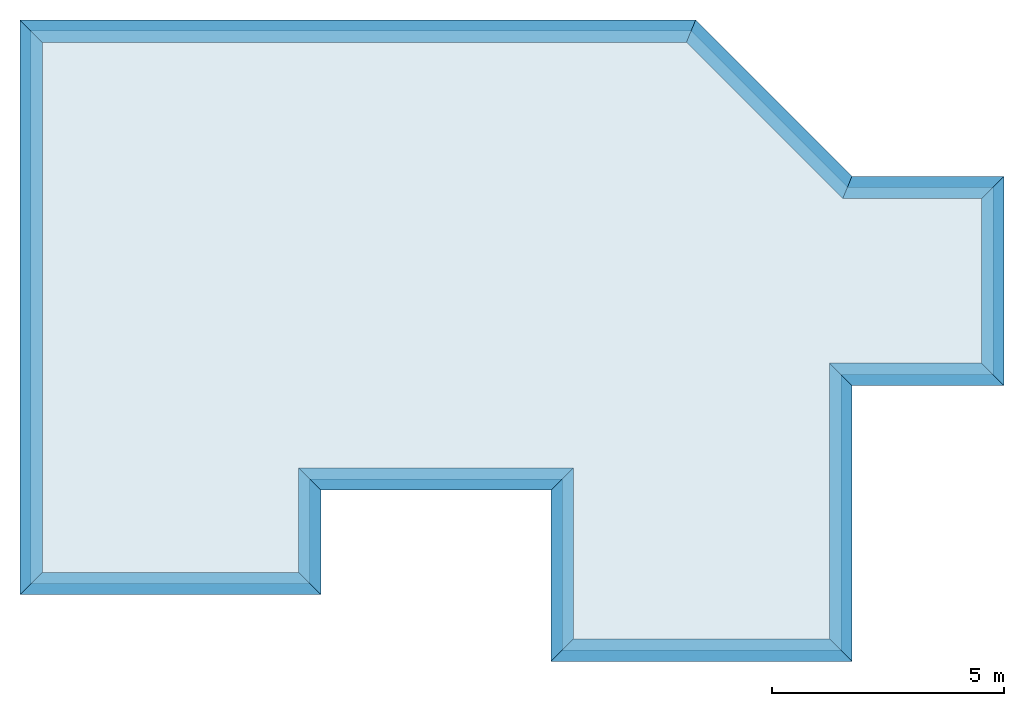
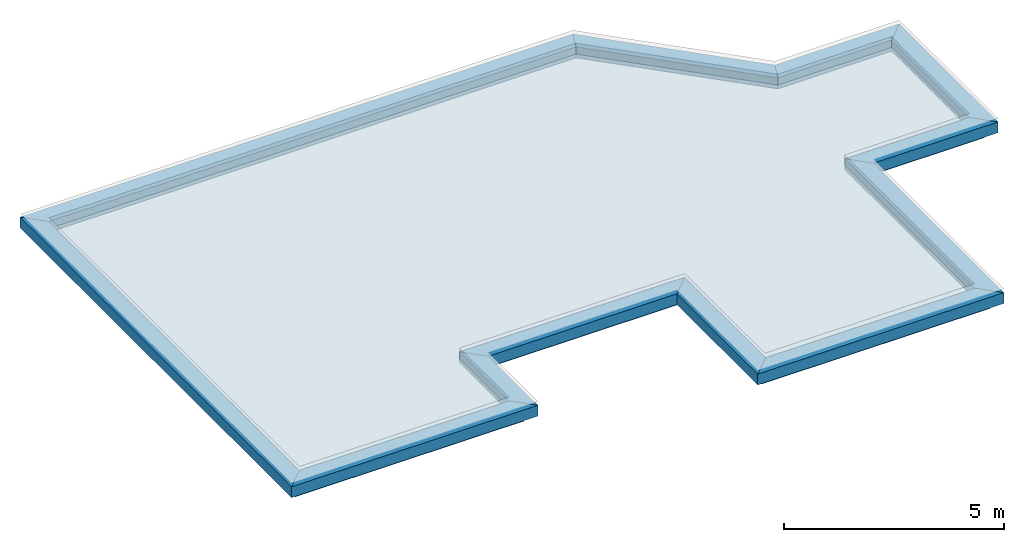
# One storey, part 1 of 3: 12 walls, 1 slab.
"""IFC4 building model written with IfcOpenShell, lengths in millimetres."""

from ifc_helpers import new_model, entity, si_unit, converted_unit, frame, origin_with_axes, origin_2d_with_axis, place, context, subcontext, project, spatial, line, indexed_curve, outline, extrude, material, layer, layer_set, layer_usage, type_object, element, save


model = new_model("IFC4")

# Units and contexts
model_context = context("Model", 3, precision=1e-05, world=origin_with_axes())
plan_context = context("Plan", 2, precision=1e-05, world=origin_2d_with_axis())
body_context = subcontext(model_context, "Body", "Model", "MODEL_VIEW")
ifc_project = project(units=[si_unit("VOLUMEUNIT", "CUBIC_METRE"), si_unit("LENGTHUNIT", "METRE", prefix="MILLI"), converted_unit("PLANEANGLEUNIT", "degree", entity("IfcReal", 0.0174532925199433), si_unit("PLANEANGLEUNIT", "RADIAN"), dimensions=[0, 0, 0, 0, 0, 0, 0]), si_unit("AREAUNIT", "SQUARE_METRE")], contexts=[model_context, plan_context])

# Site, building, storey
site_placement = place(None, origin_with_axes())
site = spatial("IfcSite", under=ifc_project, at=site_placement)
building_placement = place(site_placement, origin_with_axes())
building = spatial("IfcBuilding", under=site, at=building_placement, Name="Building")
storey_placement = place(building_placement, frame((0.0, 0.0, 2894.99998092651), z_axis=(0.0, 0.0, 1.0), x_axis=(1.0, 0.0, 0.0)))
storey = spatial("IfcBuildingStorey", under=building, at=storey_placement, Name="Dach")

# Slab
ifc_material_1 = material(Name="Beton")
ifc_layer_1 = layer(ifc_material_1, 200.0, Name="Dach Beton", Priority=10)
ifc_layer_set_1 = layer_set([ifc_layer_1], Name="Dach")
ifc_layer_usage_1 = layer_usage(ifc_layer_set_1, "AXIS3", "POSITIVE", -200.0)
slab_placement = place(storey_placement, frame((-229.997292160988, -229.997798800468, 200.000047683716), z_axis=(0.0, 0.0, 1.0), x_axis=(1.0, 0.0, 0.0)))
element("IfcSlab", 1, at=slab_placement, inside=storey, material=ifc_layer_usage_1, Name="Slab", context=body_context, shape_type="SweptSolid", body=[
    extrude(outline(indexed_curve([(229.999893188477, -170.00212097168), (229.996322631836, 11729.9970703125), (14436.1923828125, 11729.9951171875), (17798.134765625, 8368.0556640625), (20933.404296875, 8368.056640625), (20933.404296875, 4328.05712890625), (17663.404296875, 4328.05615234375), (17663.404296875, -1601.94250488281), (11652.25390625, -1601.94250488281), (11652.25390625, 2078.05444335938), (6241.12548828125, 2078.05444335938), (6241.12548828125, -170.00212097168), (229.999893188477, -170.00212097168)])), frame((0.0, 0.0, -200.0), z_axis=(0.0, 0.0, 1.0), x_axis=(1.0, 0.0, 0.0)), (0.0, 0.0, 1.0), 200.0),
])

# Walls
ifc_material_2 = material(Name="Ziegel")
ifc_layer_2 = layer(ifc_material_2, 250.0, Name="Ziegel", Priority=10)
ifc_material_3 = material()
ifc_layer_3 = layer(ifc_material_3, 200.0, Priority=1)
ifc_material_4 = material()
ifc_layer_4 = layer(ifc_material_4, 30.0000019073486, Priority=1)
ifc_layer_set_2 = layer_set([ifc_layer_2, ifc_layer_3, ifc_layer_4], Name="Wand Aussen")
ifc_layer_usage_2 = layer_usage(ifc_layer_set_2, "AXIS2", "NEGATIVE", 0.0)
wall_type = type_object("IfcWallType", Name="Attika Wand", PredefinedType="SOLIDWALL", material=ifc_layer_set_2)
wall_1_placement = place(storey_placement, frame((20453.4070428786, 7888.05856506086, 200.000047683719), z_axis=(0.0, 0.0, 1.0), x_axis=(-0.999999999999924, -3.89414367418765e-07, 0.0)))
element("IfcWall", 2, at=wall_1_placement, inside=storey, type_object=wall_type, material=ifc_layer_usage_2, Name="Wall", context=body_context, shape_type="SweptSolid", body=[
    extrude(outline(indexed_curve([(-479.999923705426, -480.000001907349), (-249.999959269832, -250.0), (0.0, 0.0), (2988.82507357195, 0.0), (2885.27166298384, -250.0), (2790.00252445273, -480.000001907349)], segments=[line(1, 2, 3, 4, 5, 6, 1)])), origin_with_axes(), (0.0, 0.0, 1.0), 300.000011920929),
])
ifc_layer_usage_3 = layer_usage(ifc_layer_set_2, "AXIS2", "POSITIVE", 0.0)
wall_2_placement = place(storey_placement, frame((20453.4070428786, 7888.05856506086, 200.000047683719), z_axis=(0.0, 0.0, 1.0), x_axis=(5.52335052361657e-07, -0.999999999999847, 0.0)))
element("IfcWall", 3, at=wall_2_placement, inside=storey, type_object=wall_type, material=ifc_layer_usage_3, Name="Wall", context=body_context, shape_type="SweptSolid", body=[
    extrude(outline(indexed_curve([(0.0, 0.0), (-249.999959269832, 250.0), (-479.999923705426, 480.000001907349), (4019.99929706253, 480.000001907349), (3789.99922295438, 250.0), (3539.99914447525, 0.0)], segments=[line(1, 2, 3, 4, 5, 6, 1)])), origin_with_axes(), (0.0, 0.0, 1.0), 300.000011920929),
])
ifc_layer_usage_4 = layer_usage(ifc_layer_set_2, "AXIS2", "NEGATIVE", 0.0)
wall_3_placement = place(storey_placement, frame((17183.4058637143, 4348.05864095665, 200.000047683719), z_axis=(0.0, 0.0, 1.0), x_axis=(0.999999999999972, 2.38418579101556e-07, 0.0)))
element("IfcWall", 4, at=wall_3_placement, inside=storey, type_object=wall_type, material=ifc_layer_usage_4, Name="Wall", context=body_context, shape_type="SweptSolid", body=[
    extrude(outline(indexed_curve([(479.999965668361, -480.000001907349), (249.999981125527, -250.0), (0.0, 0.0), (3270.00313442999, 0.0), (3520.00321290912, -250.0), (3750.00328701727, -480.000001907349)], segments=[line(1, 2, 3, 4, 5, 6, 1)])), origin_with_axes(), (0.0, 0.0, 1.0), 300.000011920929),
])
ifc_layer_usage_5 = layer_usage(ifc_layer_set_2, "AXIS2", "NEGATIVE", 0.0)
wall_4_placement = place(storey_placement, frame((17464.5819693069, 7888.05740116944, 200.000047683719), z_axis=(0.0, 0.0, 1.0), x_axis=(-0.707106960000462, 0.707106602372588, 0.0)))
element("IfcWall", 5, at=wall_4_placement, inside=storey, type_object=wall_type, material=ifc_layer_usage_5, Name="Wall", context=body_context, shape_type="SweptSolid", body=[
    extrude(outline(indexed_curve([(198.82254911922, -480.000001907349), (103.553410588109, -250.0), (0.0, 0.0), (4754.50068374135, 0.0), (4858.05398027264, -250.0), (4953.32301387148, -480.000001907349)], segments=[line(1, 2, 3, 4, 5, 6, 1)])), origin_with_axes(), (0.0, 0.0, 1.0), 300.000011920929),
])
ifc_layer_usage_6 = layer_usage(ifc_layer_set_2, "AXIS2", "NEGATIVE", 0.0)
wall_5_placement = place(storey_placement, frame((14102.6414445064, 11249.9962256279, 200.000047683719), z_axis=(0.0, 0.0, 1.0), x_axis=(-0.999999999999924, 3.89414367418765e-07, 0.0)))
element("IfcWall", 6, at=wall_5_placement, inside=storey, type_object=wall_type, material=ifc_layer_usage_6, Name="Wall", context=body_context, shape_type="SweptSolid", body=[
    extrude(outline(indexed_curve([(-198.822330130132, -480.000001907349), (-103.553296531293, -250.0), (0.0, 0.0), (13852.642040554, 0.0), (14102.6421408888, -250.0), (14332.6422351042, -480.000001907349)], segments=[line(1, 2, 3, 4, 5, 6, 1)])), origin_with_axes(), (0.0, 0.0, 1.0), 300.000011920929),
])
ifc_layer_usage_7 = layer_usage(ifc_layer_set_2, "AXIS2", "NEGATIVE", 0.0)
wall_6_placement = place(storey_placement, frame((249.999403953487, 11250.0016200458, 200.000047683719), z_axis=(0.0, 0.0, 1.0), x_axis=(1.19248806385031e-08, -1.0, 0.0)))
element("IfcWall", 7, at=wall_6_placement, inside=storey, type_object=wall_type, material=ifc_layer_usage_7, Name="Wall", context=body_context, shape_type="SweptSolid", body=[
    extrude(outline(indexed_curve([(-480.000194550227, -480.000001907349), (-250.000100334832, -250.0), (0.0, 0.0), (11400.0017154132, 0.0), (11650.0017422343, -250.0), (11880.001768817, -480.000001907349)], segments=[line(1, 2, 3, 4, 5, 6, 1)])), origin_with_axes(), (0.0, 0.0, 1.0), 300.000011920929),
])
ifc_layer_usage_8 = layer_usage(ifc_layer_set_2, "AXIS2", "NEGATIVE", 0.0)
wall_7_placement = place(storey_placement, frame((249.999539897147, -150.000095367415, 200.000047683719), z_axis=(0.0, 0.0, 1.0), x_axis=(0.999999999999993, 1.1920928955078e-07, 0.0)))
element("IfcWall", 8, at=wall_7_placement, inside=storey, type_object=wall_type, material=ifc_layer_usage_8, Name="Wall", context=body_context, shape_type="SweptSolid", body=[
    extrude(outline(indexed_curve([(-480.000053403868, -480.000001907349), (-250.000026821104, -250.0), (0.0, 0.0), (5511.12983937525, 0.0), (5761.12985030309, -250.0), (5991.12986226407, -480.000001907349)], segments=[line(1, 2, 3, 4, 5, 6, 1)])), origin_with_axes(), (0.0, 0.0, 1.0), 300.000011920929),
])
ifc_layer_usage_9 = layer_usage(ifc_layer_set_2, "AXIS2", "NEGATIVE", 0.0)
wall_8_placement = place(storey_placement, frame((5761.12937927235, -149.999438389543, 200.000047683719), z_axis=(0.0, 0.0, 1.0), x_axis=(-1.62920684942944e-07, 0.999999999999987, 0.0)))
element("IfcWall", 9, at=wall_8_placement, inside=storey, type_object=wall_type, material=ifc_layer_usage_9, Name="Wall", context=body_context, shape_type="SweptSolid", body=[
    extrude(outline(indexed_curve([(-480.000022888819, -480.000001907349), (-250.000010927849, -250.0), (0.0, 0.0), (2248.05426549667, 0.0), (1998.05432212009, -250.0), (1768.05437230628, -480.000001907349)], segments=[line(1, 2, 3, 4, 5, 6, 1)])), origin_with_axes(), (0.0, 0.0, 1.0), 300.000011920929),
])
ifc_layer_usage_10 = layer_usage(ifc_layer_set_2, "AXIS2", "POSITIVE", 0.0)
wall_9_placement = place(storey_placement, frame((11672.2561034717, 2098.05712898492, 200.000047683719), z_axis=(0.0, 0.0, 1.0), x_axis=(-0.999999999999924, -3.89414367418765e-07, 0.0)))
element("IfcWall", 10, at=wall_9_placement, inside=storey, type_object=wall_type, material=ifc_layer_usage_10, Name="Wall", context=body_context, shape_type="SweptSolid", body=[
    extrude(outline(indexed_curve([(0.0, 0.0), (250.000056623427, 250.0), (480.000110624329, 480.000001907349), (5431.1271972639, 480.000001907349), (5661.12714707771, 250.0), (5911.12709045429, 0.0)], segments=[line(1, 2, 3, 4, 5, 6, 1)])), origin_with_axes(), (0.0, 0.0, 1.0), 300.000011920929),
])
ifc_layer_usage_11 = layer_usage(ifc_layer_set_2, "AXIS2", "POSITIVE", 0.0)
wall_10_placement = place(storey_placement, frame((11672.2567030195, -1581.9412503736, 200.000047683719), z_axis=(0.0, 0.0, 1.0), x_axis=(-1.62920684942944e-07, 0.999999999999987, 0.0)))
element("IfcWall", 11, at=wall_10_placement, inside=storey, type_object=wall_type, material=ifc_layer_usage_11, Name="Wall", context=body_context, shape_type="SweptSolid", body=[
    extrude(outline(indexed_curve([(0.0, 0.0), (-250.000040730175, 250.0), (-480.000080109284, 480.000001907349), (3199.99826873424, 480.000001907349), (3429.99832273514, 250.0), (3679.99837935857, 0.0)], segments=[line(1, 2, 3, 4, 5, 6, 1)])), origin_with_axes(), (0.0, 0.0, 1.0), 300.000011920929),
])
ifc_layer_usage_12 = layer_usage(ifc_layer_set_2, "AXIS2", "POSITIVE", 0.0)
wall_11_placement = place(storey_placement, frame((17183.4068298337, -1581.93945461289, 200.000047683719), z_axis=(0.0, 0.0, 1.0), x_axis=(-0.999999999999947, -3.25841369885876e-07, 0.0)))
element("IfcWall", 12, at=wall_11_placement, inside=storey, type_object=wall_type, material=ifc_layer_usage_12, Name="Wall", context=body_context, shape_type="SweptSolid", body=[
    extrude(outline(indexed_curve([(0.0, 0.0), (-249.999959269832, 250.0), (-479.999923705426, 480.000001907349), (5991.15020692373, 480.000001907349), (5761.15016754463, 250.0), (5511.15012681445, 0.0)], segments=[line(1, 2, 3, 4, 5, 6, 1)])), origin_with_axes(), (0.0, 0.0, 1.0), 300.000011920929),
])
ifc_layer_usage_13 = layer_usage(ifc_layer_set_2, "AXIS2", "NEGATIVE", 0.0)
wall_12_placement = place(storey_placement, frame((17183.4068298337, -1581.93945461289, 200.000047683719), z_axis=(0.0, 0.0, 1.0), x_axis=(-1.62920684942944e-07, 0.999999999999987, 0.0)))
element("IfcWall", 13, at=wall_12_placement, inside=storey, type_object=wall_type, material=ifc_layer_usage_13, Name="Wall", context=body_context, shape_type="SweptSolid", body=[
    extrude(outline(indexed_curve([(-479.999923705426, -480.000001907349), (-249.999959269832, -250.0), (0.0, 0.0), (5929.99809556962, 0.0), (5679.99811444409, -250.0), (5449.99812990126, -480.000001907349)], segments=[line(1, 2, 3, 4, 5, 6, 1)])), origin_with_axes(), (0.0, 0.0, 1.0), 300.000011920929),
])

save(model, "model.ifc")
